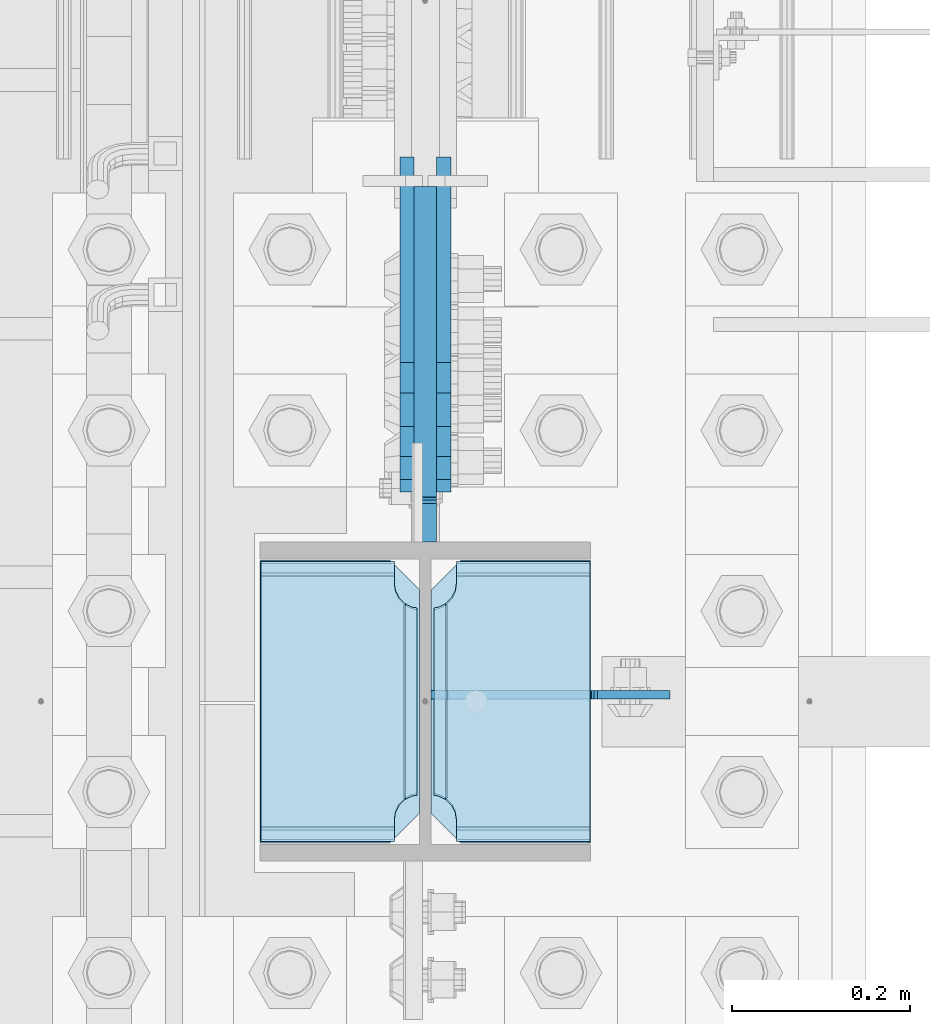
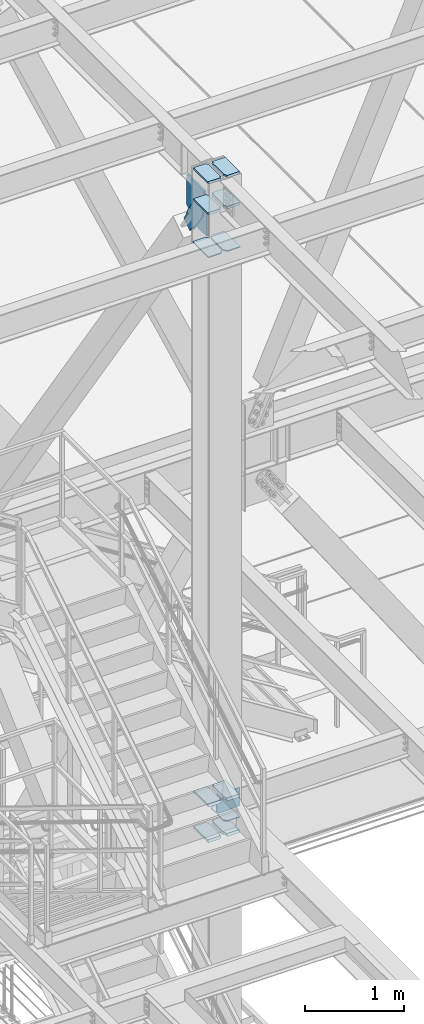
# One storey, part 3120 of 3843: 15 plates, 3 elements without a shape of their own.
"""IFC2X3 building model written with IfcOpenShell, lengths in millimetres."""

from ifc_helpers import new_model, si_unit, frame, origin_with_axes, place, context, subcontext, project, spatial, faceted_brep, material, type_object, element, aggregate, save


model = new_model("IFC2X3")

# Units and contexts
model_context = context("Model", 3, precision=1e-05, world=origin_with_axes())
body_context = subcontext(model_context, "Body", "Model", "MODEL_VIEW")
ifc_project = project(units=[si_unit("LENGTHUNIT", "METRE", prefix="MILLI"), si_unit("AREAUNIT", "SQUARE_METRE"), si_unit("VOLUMEUNIT", "CUBIC_METRE"), si_unit("MASSUNIT", "GRAM", prefix="KILO"), si_unit("TIMEUNIT", "SECOND"), si_unit("PLANEANGLEUNIT", "RADIAN"), si_unit("SOLIDANGLEUNIT", "STERADIAN"), si_unit("THERMODYNAMICTEMPERATUREUNIT", "DEGREE_CELSIUS"), si_unit("LUMINOUSINTENSITYUNIT", "LUMEN")], contexts=[model_context])

# Site, building, storey
site_placement = place(None, origin_with_axes())
site = spatial("IfcSite", under=ifc_project, at=site_placement, CompositionType="ELEMENT")
building_placement = place(site_placement, origin_with_axes())
building = spatial("IfcBuilding", under=site, at=building_placement, Name="Undefined", CompositionType="ELEMENT")
storey_placement = place(building_placement, origin_with_axes())
storey = spatial("IfcBuildingStorey", under=building, at=storey_placement, Name="Undefined", CompositionType="ELEMENT", Elevation=0.0)

# Assembly, plates
assembly_1_placement = place(storey_placement, origin_with_axes())
assembly_1 = element("IfcElementAssembly", 1, at=assembly_1_placement, inside=storey, Name="COLUMN", AssemblyPlace="NOTDEFINED", PredefinedType="RIGID_FRAME")
ifc_material_1 = material(Name="STEEL/A572-50")
plate_type_1 = type_object("IfcPlateType", PredefinedType="NOTDEFINED")
plate_1_placement = place(assembly_1_placement, frame((55745.0625, 20148.55, 41547.5150466346), z_axis=(0.0, 1.0, 0.0), x_axis=(1.0, 0.0, 0.0)))
plate_1 = element("IfcPlate", 2, at=plate_1_placement, type_object=plate_type_1, material=ifc_material_1, Name="STIFFENER", context=body_context, shape_type="Brep", body=[
    faceted_brep([(0.0, -6.3499999046162, 0.0), (0.0, -6.34999999999854, 317.5), (0.0, 6.34999999999854, 317.5), (7.27595761418343e-12, 6.3499999046162, 0.0), (146.049995422363, -6.34999999999854, 317.5), (146.049995422363, 6.34999999999854, 317.5), (179.387496948242, -6.34999999999854, 284.162498474121), (179.387496948242, 6.34999999999854, 284.162498474121), (179.387496948242, -6.34999999999854, 33.3375015258789), (179.387496948242, 6.34999999999854, 33.3375015258789), (146.050003051758, -6.34999999999854, 0.0), (146.050003051758, 6.34999999999854, 0.0)], [[[0, 1, 2, 3]], [[1, 4, 5, 2]], [[4, 6, 7, 5]], [[6, 8, 9, 7]], [[8, 10, 11, 9]], [[10, 0, 3, 11]], [[5, 7, 9, 11, 3, 2]], [[10, 8, 6, 4, 1, 0]]]),
])
plate_2_placement = place(assembly_1_placement, frame((55937.15, 20148.55, 41547.5150466346), z_axis=(0.0, 1.0, 0.0), x_axis=(1.0, 0.0, 0.0)))
plate_2 = element("IfcPlate", 3, at=plate_2_placement, type_object=plate_type_1, material=ifc_material_1, Name="STIFFENER", context=body_context, shape_type="Brep", body=[
    faceted_brep([(0.0, -6.34999999999854, 33.3375015258789), (0.0, -6.34999999999854, 284.162498474121), (0.0, 6.34999999999854, 284.162498474121), (0.0, 6.34999999999854, 33.3375015258789), (33.3375015258789, -6.34999999999854, 317.5), (33.3375015258789, 6.34999999999854, 317.5), (179.387496948242, -6.34999999999854, 317.5), (179.387496948242, 6.34999999999854, 317.5), (179.387496948242, -6.34999999999854, 0.0), (179.387496948242, 6.34999999999854, 0.0), (33.3375015258789, -6.34999999999854, 0.0), (33.3375015258789, 6.34999999999854, 0.0)], [[[0, 1, 2, 3]], [[1, 4, 5, 2]], [[4, 6, 7, 5]], [[6, 8, 9, 7]], [[8, 10, 11, 9]], [[10, 0, 3, 11]], [[5, 7, 9, 11, 3, 2]], [[10, 8, 6, 4, 1, 0]]]),
])
plate_type_2 = type_object("IfcPlateType", PredefinedType="NOTDEFINED")
plate_3_placement = place(assembly_1_placement, frame((56114.95, 20148.55, 34539.2375), z_axis=(0.0, 1.0, 0.0), x_axis=(-1.0, 0.0, 0.0)))
plate_3 = element("IfcPlate", 4, at=plate_3_placement, type_object=plate_type_2, material=ifc_material_1, Name="PLATE", context=body_context, shape_type="Brep", body=[
    faceted_brep([(0.0, -4.76249999999709, 0.0), (0.0, -4.76249999785796, 317.500000005042), (0.0, 4.76250000210712, 317.50000000505), (0.0, 4.76249999999709, 0.0), (144.462501525879, -4.76249999999709, 317.5), (144.462501525879, 4.76249999999709, 317.5), (177.800003051758, -4.76249999999709, 284.162498474121), (177.800003051758, 4.76249999999709, 284.162498474121), (177.800003051758, -4.76249999999709, 33.3375015258789), (177.800003051758, 4.76249999999709, 33.3375015258789), (144.462501525879, -4.76249999999709, 0.0), (144.462501525879, 4.76249999999709, 0.0)], [[[0, 1, 2, 3]], [[1, 4, 5, 2]], [[4, 6, 7, 5]], [[6, 8, 9, 7]], [[8, 10, 11, 9]], [[10, 0, 3, 11]], [[5, 7, 9, 11, 3, 2]], [[10, 8, 6, 4, 1, 0]]]),
])
plate_type_3 = type_object("IfcPlateType", PredefinedType="NOTDEFINED")
plate_4_placement = place(assembly_1_placement, frame((55924.45, 20146.9625, 42076.6875), z_axis=(0.0, 1.0, 0.0), x_axis=(-1.0, 0.0, 0.0)))
plate_4 = element("IfcPlate", 5, at=plate_4_placement, type_object=plate_type_3, material=ifc_material_1, Name="PLATE", context=body_context, shape_type="Brep", body=[
    faceted_brep([(16.0066099053001, 11.1125000000029, 270.167643514866), (16.0066099053001, 11.1125000000029, 50.50735648513), (8.830160850026, -1.31775402112544, 54.1639399157939), (3.17499995231628, -11.1125000000029, 55.059629409523), (3.17499995231628, -11.1125000000029, 265.615370590476), (8.830160850026, -1.31775402112544, 266.511060084205), (28.5750007629395, 11.1125000000029, 304.668390094703), (28.5750007629395, -11.1125000000029, 317.500000047683), (178.593800000002, -11.1125000000029, 317.500000047683), (178.593800000002, 11.1125000000029, 304.668390094703), (178.593800000002, 11.1125000000029, 16.0066099052965), (178.593800000002, -11.1125000000029, 3.17499995231628), (28.5750007629395, -11.1125000000029, 3.17499995231628), (28.5750007629395, 11.1125000000029, 16.0066099052965), (8.830160850026, -11.1125000000029, 266.511060084205), (16.7959640327026, -11.1125000000029, 270.569839531443), (16.7959640327026, 11.1125000000029, 270.569839531443), (23.1176612314957, -11.1125000000029, 276.891536730236), (23.1176612314957, 11.1125000000029, 276.891536730236), (27.1764406787333, -11.1125000000029, 284.857339912913), (27.1764406787333, 11.1125000000029, 284.857339912913), (28.5750007629395, -11.1125000000029, 293.687500762939), (28.5750007629395, 11.1125000000029, 293.687500762939), (28.5750007629395, -11.1125000000029, 26.9874992370605), (28.5750007629395, 11.1125000000029, 26.9874992370605), (27.1764406787333, -11.1125000000029, 35.8176600870866), (27.1764406787333, 11.1125000000029, 35.8176600870866), (23.1176612314957, -11.1125000000029, 43.7834632697632), (23.1176612314957, 11.1125000000029, 43.7834632697632), (16.7959640327026, -11.1125000000029, 50.1051604685563), (16.7959640327026, 11.1125000000029, 50.1051604685563), (8.830160850026, -11.1125000000029, 54.1639399157939)], [[[0, 1, 2, 3, 4, 5]], [[6, 7, 8, 9]], [[10, 11, 12, 13]], [[14, 5, 4]], [[14, 15, 16, 0, 5]], [[15, 17, 18, 16]], [[17, 19, 20, 18]], [[19, 21, 22, 20]], [[22, 21, 7, 6]], [[11, 10, 9, 8]], [[23, 24, 13, 12]], [[23, 25, 26, 24]], [[25, 27, 28, 26]], [[27, 29, 30, 28]], [[30, 29, 31, 2, 1]], [[31, 3, 2]], [[16, 18, 20, 22, 6, 9, 10, 13, 24, 26, 28, 30, 1, 0]], [[31, 29, 27, 25, 23, 12, 11, 8, 7, 21, 19, 17, 15, 14, 4, 3]]]),
])
plate_5_placement = place(assembly_1_placement, frame((55924.45, 20146.9625, 42457.6875), z_axis=(0.0, 1.0, 0.0), x_axis=(-1.0, 0.0, 0.0)))
plate_5 = element("IfcPlate", 6, at=plate_5_placement, type_object=plate_type_3, material=ifc_material_1, Name="PLATE", context=body_context, shape_type="Brep", body=[
    faceted_brep([(16.0066099053001, 11.1125000000029, 270.167643514866), (16.0066099053001, 11.1125000000029, 50.50735648513), (8.830160850026, -1.31719474220154, 54.1639399157939), (3.17499995231628, -11.1125000000029, 55.059629409523), (3.17499995231628, -11.1125000000029, 265.615370590476), (8.830160850026, -1.31719474219426, 266.511060084205), (178.593800000002, 11.1125000000029, 16.0066099052965), (178.593800000002, -11.1125000000029, 3.17499995231628), (28.5750007629395, -11.1125000000029, 3.17499995231628), (28.5750007629395, 11.1125000000029, 16.0066099052965), (28.5750007629395, 11.1125000000029, 304.668390094703), (28.5750007629395, -11.1125000000029, 317.500000047683), (178.593800000002, -11.1125000000029, 317.500000047683), (178.593800000002, 11.1125000000029, 304.668390094703), (8.830160850026, -11.1125000000029, 266.511060084205), (16.7959640327026, -11.1125000000029, 270.569839531443), (16.7959640327026, 11.1125000000029, 270.569839531443), (23.1176612314957, -11.1125000000029, 276.891536730236), (23.1176612314957, 11.1125000000029, 276.891536730236), (27.1764406787333, -11.1125000000029, 284.857339912913), (27.1764406787333, 11.1125000000029, 284.857339912913), (28.5750007629395, -11.1125000000029, 293.687500762939), (28.5750007629395, 11.1125000000029, 293.687500762939), (28.5750007629395, -11.1125000000029, 26.9874992370605), (28.5750007629395, 11.1125000000029, 26.9874992370605), (27.1764406787333, -11.1125000000029, 35.8176600870866), (27.1764406787333, 11.1125000000029, 35.8176600870866), (23.1176612314957, -11.1125000000029, 43.7834632697632), (23.1176612314957, 11.1125000000029, 43.7834632697632), (16.7959640327026, -11.1125000000029, 50.1051604685563), (16.7959640327026, 11.1125000000029, 50.1051604685563), (8.830160850026, -11.1125000000029, 54.1639399157939)], [[[0, 1, 2, 3, 4, 5]], [[6, 7, 8, 9]], [[10, 11, 12, 13]], [[14, 5, 4]], [[14, 15, 16, 0, 5]], [[15, 17, 18, 16]], [[17, 19, 20, 18]], [[19, 21, 22, 20]], [[22, 21, 11, 10]], [[7, 6, 13, 12]], [[23, 24, 9, 8]], [[23, 25, 26, 24]], [[25, 27, 28, 26]], [[27, 29, 30, 28]], [[30, 29, 31, 2, 1]], [[31, 3, 2]], [[16, 18, 20, 22, 10, 13, 6, 9, 24, 26, 28, 30, 1, 0]], [[31, 29, 27, 25, 23, 8, 7, 12, 11, 21, 19, 17, 15, 14, 4, 3]]]),
])
plate_6_placement = place(assembly_1_placement, frame((56115.7438, 20146.9625, 42076.6875), z_axis=(0.0, 1.0, 0.0), x_axis=(-1.0, 0.0, 0.0)))
plate_6 = element("IfcPlate", 7, at=plate_6_placement, type_object=plate_type_3, material=ifc_material_1, Name="PLATE", context=body_context, shape_type="Brep", body=[
    faceted_brep([(162.587190094702, 11.1125000000029, 50.50735648513), (162.587190094702, 11.1125000000029, 270.167643514869), (169.763639149976, -1.31775402112544, 266.511060084205), (175.418800047686, -11.1125000000029, 265.615370590476), (175.418800047686, -11.1125000000029, 55.059629409523), (169.763639149976, -1.31775402112544, 54.1639399157939), (0.0, 11.1125000000029, 304.668390094703), (0.0, -11.1125000000029, 317.500000047683), (150.018799237063, -11.1125000000029, 317.500000047683), (150.018799237063, 11.1125000000029, 304.668390094703), (150.018799237063, 11.1125000000029, 16.0066099052965), (150.018799237063, -11.1125000000029, 3.17499995231628), (0.0, -11.1125000000029, 3.17499995231628), (0.0, 11.1125000000029, 16.0066099052965), (150.018799237063, -11.1125000000029, 293.687500762939), (150.018799237063, 11.1125000000029, 293.687500762939), (151.417359321269, -11.1125000000029, 284.857339912913), (151.417359321269, 11.1125000000029, 284.857339912913), (155.476138768507, -11.1125000000029, 276.891536730236), (155.476138768507, 11.1125000000029, 276.891536730236), (161.7978359673, -11.1125000000029, 270.569839531443), (161.7978359673, 11.1125000000029, 270.569839531443), (169.763639149976, -11.1125000000029, 266.511060084205), (169.763639149976, -11.1125000000029, 54.1639399157939), (161.7978359673, -11.1125000000029, 50.1051604685563), (161.7978359673, 11.1125000000029, 50.1051604685563), (155.476138768507, -11.1125000000029, 43.7834632697632), (155.476138768507, 11.1125000000029, 43.7834632697632), (151.417359321269, -11.1125000000029, 35.8176600870866), (151.417359321269, 11.1125000000029, 35.8176600870866), (150.018799237063, -11.1125000000029, 26.9874992370605), (150.018799237063, 11.1125000000029, 26.9874992370605)], [[[0, 1, 2, 3, 4, 5]], [[6, 7, 8, 9]], [[10, 11, 12, 13]], [[13, 12, 7, 6]], [[14, 15, 9, 8]], [[14, 16, 17, 15]], [[16, 18, 19, 17]], [[18, 20, 21, 19]], [[21, 20, 22, 2, 1]], [[22, 3, 2]], [[23, 5, 4]], [[23, 24, 25, 0, 5]], [[24, 26, 27, 25]], [[26, 28, 29, 27]], [[28, 30, 31, 29]], [[31, 30, 11, 10]], [[25, 27, 29, 31, 10, 13, 6, 9, 15, 17, 19, 21, 1, 0]], [[11, 30, 28, 26, 24, 23, 4, 3, 22, 20, 18, 16, 14, 8, 7, 12]]]),
])
plate_7_placement = place(assembly_1_placement, frame((56115.7438, 20146.9625, 42457.6875), z_axis=(0.0, 1.0, 0.0), x_axis=(-1.0, 0.0, 0.0)))
plate_7 = element("IfcPlate", 8, at=plate_7_placement, type_object=plate_type_3, material=ifc_material_1, Name="PLATE", context=body_context, shape_type="Brep", body=[
    faceted_brep([(162.587190094702, 11.1125000000029, 50.50735648513), (162.587190094702, 11.1125000000029, 270.167643514869), (169.763639149976, -1.31719474220154, 266.511060084205), (175.418800047686, -11.1125000000029, 265.615370590476), (175.418800047686, -11.1125000000029, 55.059629409523), (169.763639149976, -1.31719474220154, 54.1639399157939), (150.018799237063, 11.1125000000029, 16.0066099052965), (150.018799237063, -11.1125000000029, 3.17499995231628), (0.0, -11.1125000000029, 3.17499995231628), (0.0, 11.1125000000029, 16.0066099052965), (0.0, 11.1125000000029, 304.668390094703), (0.0, -11.1125000000029, 317.500000047683), (150.018799237063, -11.1125000000029, 317.500000047683), (150.018799237063, 11.1125000000029, 304.668390094703), (150.018799237063, -11.1125000000029, 293.687500762939), (150.018799237063, 11.1125000000029, 293.687500762939), (151.417359321269, -11.1125000000029, 284.857339912913), (151.417359321269, 11.1125000000029, 284.857339912913), (155.476138768507, -11.1125000000029, 276.891536730236), (155.476138768507, 11.1125000000029, 276.891536730236), (161.7978359673, -11.1125000000029, 270.569839531443), (161.7978359673, 11.1125000000029, 270.569839531443), (169.763639149976, -11.1125000000029, 266.511060084205), (169.763639149976, -11.1125000000029, 54.1639399157939), (161.7978359673, -11.1125000000029, 50.1051604685563), (161.7978359673, 11.1125000000029, 50.1051604685563), (155.476138768507, -11.1125000000029, 43.7834632697632), (155.476138768507, 11.1125000000029, 43.7834632697632), (151.417359321269, -11.1125000000029, 35.8176600870866), (151.417359321269, 11.1125000000029, 35.8176600870866), (150.018799237063, -11.1125000000029, 26.9874992370605), (150.018799237063, 11.1125000000029, 26.9874992370605)], [[[0, 1, 2, 3, 4, 5]], [[6, 7, 8, 9]], [[10, 11, 12, 13]], [[9, 8, 11, 10]], [[14, 15, 13, 12]], [[14, 16, 17, 15]], [[16, 18, 19, 17]], [[18, 20, 21, 19]], [[21, 20, 22, 2, 1]], [[22, 3, 2]], [[23, 5, 4]], [[23, 24, 25, 0, 5]], [[24, 26, 27, 25]], [[26, 28, 29, 27]], [[28, 30, 31, 29]], [[31, 30, 7, 6]], [[25, 27, 29, 31, 6, 9, 10, 13, 15, 17, 19, 21, 1, 0]], [[7, 30, 28, 26, 24, 23, 4, 3, 22, 20, 18, 16, 14, 12, 11, 8]]]),
])
plate_type_4 = type_object("IfcPlateType", PredefinedType="NOTDEFINED")
plate_8_placement = place(assembly_1_placement, frame((55930.8, 20885.9556735903, 42065.575), z_axis=(0.0, 0.0, -1.0), x_axis=(0.0, -1.0, 0.0)))
plate_8 = element("IfcPlate", 9, at=plate_8_placement, type_object=plate_type_4, material=ifc_material_1, Name="CB", context=body_context, shape_type="Brep", body=[
    faceted_brep([(348.468173590347, -12.6999999999971, 0.0), (348.468173590347, 12.6999999999971, 0.0), (348.468173590347, 12.6999999999971, 25.4000001907334), (348.468173590347, -12.6999999999971, 25.4000001907334), (349.434903512934, 12.6999999999971, 30.2600797087798), (349.434903512934, -12.6999999999971, 30.2600797087798), (352.187917413412, 12.6999999999971, 34.3802561769335), (352.187917413412, -12.6999999999971, 34.3802561769335), (356.308093881566, 12.6999999999971, 37.1332700774074), (356.308093881566, -12.6999999999971, 37.1332700774074), (361.168173399612, 12.6999999999971, 38.0999999999985), (361.168173399612, -12.6999999999971, 38.0999999999985), (399.268173590346, -12.6999999999971, 38.0999999999985), (399.268173590346, 12.6999999999971, 38.0999999999985), (0.0, -12.6999999999971, 0.0), (0.0, -12.6999999999971, 369.765843106718), (0.0, 12.6999999999971, 369.765843106718), (0.0, 12.6999999999971, 0.0), (223.964095792653, -12.6999999999971, 524.40995336543), (223.964095792653, 12.6999999999971, 524.40995336543), (399.268173590346, -12.6999999999971, 524.40995336543), (399.268173590346, 12.6999999999971, 524.40995336543)], [[[0, 1, 2, 3]], [[3, 2, 4, 5]], [[5, 4, 6, 7]], [[7, 6, 8, 9]], [[9, 8, 10, 11]], [[12, 11, 10, 13]], [[14, 15, 16, 17]], [[15, 18, 19, 16]], [[18, 20, 21, 19]], [[21, 20, 12, 13]], [[8, 6, 4, 2, 1, 17, 16, 19, 21, 13, 10]], [[14, 17, 1, 0]], [[20, 18, 15, 14, 0, 3, 5, 7, 9, 11, 12]]]),
])

# Assembly, plate
assembly_2_placement = place(storey_placement, origin_with_axes())
assembly_2 = element("IfcElementAssembly", 10, at=assembly_2_placement, inside=storey, AssemblyPlace="NOTDEFINED", PredefinedType="RIGID_FRAME")
ifc_material_2 = material(Name="STEEL/A36")
plate_type_5 = type_object("IfcPlateType", PredefinedType="NOTDEFINED")
plate_9_placement = place(assembly_2_placement, frame((55910.1625, 20879.4458543125, 41567.8473840328), z_axis=(0.0, -0.822893061718405, -0.568196276805568), x_axis=(0.0, 0.568196276805568, -0.822893061718405)))
plate_9 = element("IfcPlate", 11, at=plate_9_placement, type_object=plate_type_5, material=ifc_material_2, context=body_context, shape_type="Brep", body=[
    faceted_brep([(0.0, -7.9375, 0.0), (-101.600000000672, -7.9375, -21.7975798491389), (-101.600000000672, 7.9375, -21.7975798491389), (0.0, 7.9375, 0.0), (-320.921138855079, -7.9375, -21.7975798491389), (-320.921138855079, 7.9375, -21.7975798491389), (-357.371735787896, -7.9375, -14.5471053208457), (-357.371735787896, 7.9375, -14.5471053208457), (-388.273059763174, -7.9375, 6.10049924286432), (-388.273059763174, 7.9375, 6.10049924286432), (-408.920664326874, -7.9375, 37.0018232181319), (-408.920664326874, 7.9375, 37.0018232181319), (-416.171138855196, -7.9375, 73.4524201520326), (-416.171138855196, 7.9375, 73.4524201520326), (-408.920664326884, -7.9375, 109.903017084842), (-408.920664326884, 7.9375, 109.903017084842), (-388.273059763185, -7.9375, 140.804341060124), (-388.273059763185, 7.9375, 140.804341060124), (-357.371735787903, -7.9375, 161.451945623819), (-357.371735787903, 7.9375, 161.451945623819), (-320.921138854563, -7.9375, 168.702420152127), (-320.921138854563, 7.9375, 168.702420152127), (-101.600000000686, -7.9375, 168.702420152142), (-101.600000000686, 7.9375, 168.702420152142), (-3.63797880709171e-12, -7.9375, 146.90484030301), (-3.63797880709171e-12, 7.9375, 146.90484030301), (69.8500000004642, -7.9375, 146.904840303017), (69.8500000004642, 7.9375, 146.904840303017), (69.850000000486, -7.9375, 2.91038304567337e-11), (69.850000000486, 7.9375, 2.91038304567337e-11)], [[[0, 1, 2, 3]], [[1, 4, 5, 2]], [[4, 6, 7, 5]], [[6, 8, 9, 7]], [[8, 10, 11, 9]], [[10, 12, 13, 11]], [[12, 14, 15, 13]], [[14, 16, 17, 15]], [[16, 18, 19, 17]], [[18, 20, 21, 19]], [[20, 22, 23, 21]], [[22, 24, 25, 23]], [[24, 26, 27, 25]], [[26, 28, 29, 27]], [[28, 0, 3, 29]], [[5, 7, 9, 11, 13, 15, 17, 19, 21, 23, 25, 27, 29, 3, 2]], [[28, 26, 24, 22, 20, 18, 16, 14, 12, 10, 8, 6, 4, 1, 0]]]),
])
aggregate(assembly_2, [plate_9])

assembly_3_placement = place(storey_placement, origin_with_axes())
assembly_3 = element("IfcElementAssembly", 12, at=assembly_3_placement, inside=storey, AssemblyPlace="NOTDEFINED", PredefinedType="RIGID_FRAME")
plate_10_placement = place(assembly_3_placement, frame((55951.4375, 20879.4458543125, 41567.8473840328), z_axis=(0.0, -0.822893061718405, -0.568196276805568), x_axis=(0.0, 0.568196276805568, -0.822893061718405)))
plate_10 = element("IfcPlate", 13, at=plate_10_placement, type_object=plate_type_5, material=ifc_material_2, context=body_context, shape_type="Brep", body=[
    faceted_brep([(0.0, -7.9375, 0.0), (-101.600000000672, -7.9375, -21.7975798491389), (-101.600000000672, 7.9375, -21.7975798491389), (0.0, 7.9375, 0.0), (-320.921138855079, -7.9375, -21.7975798491389), (-320.921138855079, 7.9375, -21.7975798491389), (-357.371735787896, -7.9375, -14.5471053208457), (-357.371735787896, 7.9375, -14.5471053208457), (-388.273059763174, -7.9375, 6.10049924286432), (-388.273059763174, 7.9375, 6.10049924286432), (-408.920664326874, -7.9375, 37.0018232181319), (-408.920664326874, 7.9375, 37.0018232181319), (-416.171138855196, -7.9375, 73.4524201520326), (-416.171138855196, 7.9375, 73.4524201520326), (-408.920664326884, -7.9375, 109.903017084842), (-408.920664326884, 7.9375, 109.903017084842), (-388.273059763185, -7.9375, 140.804341060124), (-388.273059763185, 7.9375, 140.804341060124), (-357.371735787903, -7.9375, 161.451945623819), (-357.371735787903, 7.9375, 161.451945623819), (-320.921138854563, -7.9375, 168.702420152127), (-320.921138854563, 7.9375, 168.702420152127), (-101.600000000686, -7.9375, 168.702420152142), (-101.600000000686, 7.9375, 168.702420152142), (-3.63797880709171e-12, -7.9375, 146.90484030301), (-3.63797880709171e-12, 7.9375, 146.90484030301), (69.8500000004642, -7.9375, 146.904840303017), (69.8500000004642, 7.9375, 146.904840303017), (69.850000000486, -7.9375, 2.91038304567337e-11), (69.850000000486, 7.9375, 2.91038304567337e-11)], [[[0, 1, 2, 3]], [[1, 4, 5, 2]], [[4, 6, 7, 5]], [[6, 8, 9, 7]], [[8, 10, 11, 9]], [[10, 12, 13, 11]], [[12, 14, 15, 13]], [[14, 16, 17, 15]], [[16, 18, 19, 17]], [[18, 20, 21, 19]], [[20, 22, 23, 21]], [[22, 24, 25, 23]], [[24, 26, 27, 25]], [[26, 28, 29, 27]], [[28, 0, 3, 29]], [[5, 7, 9, 11, 13, 15, 17, 19, 21, 23, 25, 27, 29, 3, 2]], [[28, 26, 24, 22, 20, 18, 16, 14, 12, 10, 8, 6, 4, 1, 0]]]),
])
aggregate(assembly_3, [plate_10])

# Plate
plate_type_6 = type_object("IfcPlateType", PredefinedType="NOTDEFINED")
plate_11_placement = place(assembly_1_placement, frame((55924.45, 20148.55, 34359.85), z_axis=(0.0, 1.0, 0.0), x_axis=(-1.0, 0.0, 0.0)))
plate_11 = element("IfcPlate", 14, at=plate_11_placement, type_object=plate_type_6, material=ifc_material_1, Name="PLATE", context=body_context, shape_type="Brep", body=[
    faceted_brep([(16.7959640327026, 10.8922022167681, 267.394839531444), (17.8396965694919, 12.6999999999971, 268.438572068233), (17.8396965694919, 12.6999999999971, 49.061427931767), (16.7959640327026, 10.8922022167681, 50.1051604685563), (8.830160850026, -2.90497361872258, 54.1639399157939), (3.17499995231628, -12.6999999999971, 55.059629409523), (3.17499995231628, -12.6999999999971, 262.440370590477), (8.830160850026, -2.90497361872258, 263.33606008421), (28.5750007629395, 12.6999999999971, 299.65980343051), (28.5750007629395, -12.6999999999971, 314.324500047685), (178.593800000002, -12.6999999999971, 314.324500047685), (178.593800000002, 12.6999999999971, 299.65980343051), (178.593800000002, 12.6999999999971, 17.8391965694937), (178.593800000002, -12.6999999999971, 3.174499952318), (28.5750007629395, -12.6999999999971, 3.174499952318), (28.5750007629395, 12.6999999999971, 17.8391965694937), (8.830160850026, -12.6999999999971, 263.33606008421), (16.7959640327026, -12.6999999999971, 267.394839531444), (23.1176612314957, -12.6999999999971, 273.716536730237), (23.1176612314957, 12.6999999999971, 273.716536730237), (27.1764406787333, -12.6999999999971, 281.682339912913), (27.1764406787333, 12.6999999999971, 281.682339912913), (28.5750007629395, -12.6999999999971, 290.512500762939), (28.5750007629395, 12.6999999999971, 290.512500762939), (28.5750007629395, -12.6999999999971, 26.9874992370605), (28.5750007629395, 12.6999999999971, 26.9874992370605), (27.1764406787333, -12.6999999999971, 35.8176600870866), (27.1764406787333, 12.6999999999971, 35.8176600870866), (23.1176612314957, -12.6999999999971, 43.7834632697632), (23.1176612314957, 12.6999999999971, 43.7834632697632), (16.7959640327026, -12.6999999999971, 50.1051604685563), (8.830160850026, -12.6999999999971, 54.1639399157939)], [[[0, 1, 2, 3, 4, 5, 6, 7]], [[8, 9, 10, 11]], [[12, 13, 14, 15]], [[16, 7, 6]], [[16, 17, 0, 7]], [[17, 18, 19, 1, 0]], [[18, 20, 21, 19]], [[20, 22, 23, 21]], [[23, 22, 9, 8]], [[13, 12, 11, 10]], [[24, 25, 15, 14]], [[24, 26, 27, 25]], [[26, 28, 29, 27]], [[29, 28, 30, 3, 2]], [[30, 31, 4, 3]], [[31, 5, 4]], [[19, 21, 23, 8, 11, 12, 15, 25, 27, 29, 2, 1]], [[31, 30, 28, 26, 24, 14, 13, 10, 9, 22, 20, 18, 17, 16, 6, 5]]]),
])

plate_12_placement = place(assembly_1_placement, frame((55924.45, 20148.55, 34798.0), z_axis=(0.0, 1.0, 0.0), x_axis=(-1.0, 0.0, 0.0)))
plate_12 = element("IfcPlate", 15, at=plate_12_placement, type_object=plate_type_6, material=ifc_material_1, Name="PLATE", context=body_context, shape_type="Brep", body=[
    faceted_brep([(16.7959640327026, 10.8922022167681, 267.394839531444), (17.8396965694919, 12.6999999999971, 268.438572068233), (17.8396965694919, 12.6999999999971, 49.061427931767), (16.7959640327026, 10.8922022167681, 50.1051604685563), (8.830160850026, -2.90497361872258, 54.1639399157939), (3.17499995231628, -12.6999999999971, 55.059629409523), (3.17499995231628, -12.6999999999971, 262.440370590477), (8.830160850026, -2.90497361872258, 263.33606008421), (28.5750007629395, 12.6999999999971, 299.65980343051), (28.5750007629395, -12.6999999999971, 314.324500047685), (178.593800000002, -12.6999999999971, 314.324500047685), (178.593800000002, 12.6999999999971, 299.65980343051), (178.593800000002, 12.6999999999971, 17.8391965694937), (178.593800000002, -12.6999999999971, 3.174499952318), (28.5750007629395, -12.6999999999971, 3.174499952318), (28.5750007629395, 12.6999999999971, 17.8391965694937), (8.830160850026, -12.6999999999971, 263.33606008421), (16.7959640327026, -12.6999999999971, 267.394839531444), (23.1176612314957, -12.6999999999971, 273.716536730237), (23.1176612314957, 12.6999999999971, 273.716536730237), (27.1764406787333, -12.6999999999971, 281.682339912913), (27.1764406787333, 12.6999999999971, 281.682339912913), (28.5750007629395, -12.6999999999971, 290.512500762939), (28.5750007629395, 12.6999999999971, 290.512500762939), (28.5750007629395, -12.6999999999971, 26.9874992370605), (28.5750007629395, 12.6999999999971, 26.9874992370605), (27.1764406787333, -12.6999999999971, 35.8176600870866), (27.1764406787333, 12.6999999999971, 35.8176600870866), (23.1176612314957, -12.6999999999971, 43.7834632697632), (23.1176612314957, 12.6999999999971, 43.7834632697632), (16.7959640327026, -12.6999999999971, 50.1051604685563), (8.830160850026, -12.6999999999971, 54.1639399157939)], [[[0, 1, 2, 3, 4, 5, 6, 7]], [[8, 9, 10, 11]], [[12, 13, 14, 15]], [[16, 7, 6]], [[16, 17, 0, 7]], [[17, 18, 19, 1, 0]], [[18, 20, 21, 19]], [[20, 22, 23, 21]], [[23, 22, 9, 8]], [[13, 12, 11, 10]], [[24, 25, 15, 14]], [[24, 26, 27, 25]], [[26, 28, 29, 27]], [[29, 28, 30, 3, 2]], [[30, 31, 4, 3]], [[31, 5, 4]], [[19, 21, 23, 8, 11, 12, 15, 25, 27, 29, 2, 1]], [[31, 30, 28, 26, 24, 14, 13, 10, 9, 22, 20, 18, 17, 16, 6, 5]]]),
])

plate_13_placement = place(assembly_1_placement, frame((56115.7438, 20148.55, 34359.85), z_axis=(0.0, 1.0, 0.0), x_axis=(-1.0, 0.0, 0.0)))
plate_13 = element("IfcPlate", 16, at=plate_13_placement, type_object=plate_type_6, material=ifc_material_1, Name="PLATE", context=body_context, shape_type="Brep", body=[
    faceted_brep([(161.7978359673, 10.8922022167681, 50.1051604685563), (160.75410343051, 12.6999999999971, 49.061427931767), (160.75410343051, 12.6999999999971, 268.438572068233), (161.7978359673, 10.8922022167681, 267.394839531444), (169.763639149976, -2.90497361872258, 263.336060084206), (175.418800047686, -12.6999999999971, 262.440370590477), (175.418800047686, -12.6999999999971, 55.059629409523), (169.763639149976, -2.90497361872258, 54.1639399157939), (0.0, 12.6999999999971, 299.65980343051), (0.0, -12.6999999999971, 314.324500047685), (150.018799237063, -12.6999999999971, 314.324500047685), (150.018799237063, 12.6999999999971, 299.65980343051), (150.018799237063, 12.6999999999971, 17.8391965694937), (150.018799237063, -12.6999999999971, 3.174499952318), (0.0, -12.6999999999971, 3.17449995232164), (0.0, 12.6999999999971, 17.8391965694973), (150.018799237063, -12.6999999999971, 290.512500762939), (150.018799237063, 12.6999999999971, 290.512500762939), (151.417359321269, -12.6999999999971, 281.682339912913), (151.417359321269, 12.6999999999971, 281.682339912913), (155.476138768507, -12.6999999999971, 273.716536730237), (155.476138768507, 12.6999999999971, 273.716536730237), (161.7978359673, -12.6999999999971, 267.394839531444), (169.763639149976, -12.6999999999971, 263.336060084206), (169.763639149976, -12.6999999999971, 54.1639399157939), (161.7978359673, -12.6999999999971, 50.1051604685563), (155.476138768507, -12.6999999999971, 43.7834632697632), (155.476138768507, 12.6999999999971, 43.7834632697632), (151.417359321269, -12.6999999999971, 35.8176600870866), (151.417359321269, 12.6999999999971, 35.8176600870866), (150.018799237063, -12.6999999999971, 26.9874992370605), (150.018799237063, 12.6999999999971, 26.9874992370605)], [[[0, 1, 2, 3, 4, 5, 6, 7]], [[8, 9, 10, 11]], [[12, 13, 14, 15]], [[15, 14, 9, 8]], [[16, 17, 11, 10]], [[16, 18, 19, 17]], [[18, 20, 21, 19]], [[21, 20, 22, 3, 2]], [[22, 23, 4, 3]], [[23, 5, 4]], [[24, 7, 6]], [[24, 25, 0, 7]], [[25, 26, 27, 1, 0]], [[26, 28, 29, 27]], [[28, 30, 31, 29]], [[31, 30, 13, 12]], [[27, 29, 31, 12, 15, 8, 11, 17, 19, 21, 2, 1]], [[13, 30, 28, 26, 25, 24, 6, 5, 23, 22, 20, 18, 16, 10, 9, 14]]]),
])

plate_14_placement = place(assembly_1_placement, frame((56115.7438, 20148.55, 34798.0), z_axis=(0.0, 1.0, 0.0), x_axis=(-1.0, 0.0, 0.0)))
plate_14 = element("IfcPlate", 17, at=plate_14_placement, type_object=plate_type_6, material=ifc_material_1, Name="PLATE", context=body_context, shape_type="Brep", body=[
    faceted_brep([(161.7978359673, 10.8922022167681, 50.1051604685563), (160.75410343051, 12.6999999999971, 49.061427931767), (160.75410343051, 12.6999999999971, 268.438572068233), (161.7978359673, 10.8922022167681, 267.394839531444), (169.763639149976, -2.90497361872258, 263.336060084206), (175.418800047686, -12.6999999999971, 262.440370590477), (175.418800047686, -12.6999999999971, 55.059629409523), (169.763639149976, -2.90497361872258, 54.1639399157939), (0.0, 12.6999999999971, 299.65980343051), (0.0, -12.6999999999971, 314.324500047685), (150.018799237063, -12.6999999999971, 314.324500047685), (150.018799237063, 12.6999999999971, 299.65980343051), (150.018799237063, 12.6999999999971, 17.8391965694937), (150.018799237063, -12.6999999999971, 3.174499952318), (0.0, -12.6999999999971, 3.17449995232164), (0.0, 12.6999999999971, 17.8391965694973), (150.018799237063, -12.6999999999971, 290.512500762939), (150.018799237063, 12.6999999999971, 290.512500762939), (151.417359321269, -12.6999999999971, 281.682339912913), (151.417359321269, 12.6999999999971, 281.682339912913), (155.476138768507, -12.6999999999971, 273.716536730237), (155.476138768507, 12.6999999999971, 273.716536730237), (161.7978359673, -12.6999999999971, 267.394839531444), (169.763639149976, -12.6999999999971, 263.336060084206), (169.763639149976, -12.6999999999971, 54.1639399157939), (161.7978359673, -12.6999999999971, 50.1051604685563), (155.476138768507, -12.6999999999971, 43.7834632697632), (155.476138768507, 12.6999999999971, 43.7834632697632), (151.417359321269, -12.6999999999971, 35.8176600870866), (151.417359321269, 12.6999999999971, 35.8176600870866), (150.018799237063, -12.6999999999971, 26.9874992370605), (150.018799237063, 12.6999999999971, 26.9874992370605)], [[[0, 1, 2, 3, 4, 5, 6, 7]], [[8, 9, 10, 11]], [[12, 13, 14, 15]], [[15, 14, 9, 8]], [[16, 17, 11, 10]], [[16, 18, 19, 17]], [[18, 20, 21, 19]], [[21, 20, 22, 3, 2]], [[22, 23, 4, 3]], [[23, 5, 4]], [[24, 7, 6]], [[24, 25, 0, 7]], [[25, 26, 27, 1, 0]], [[26, 28, 29, 27]], [[28, 30, 31, 29]], [[31, 30, 13, 12]], [[27, 29, 31, 12, 15, 8, 11, 17, 19, 21, 2, 1]], [[13, 30, 28, 26, 25, 24, 6, 5, 23, 22, 20, 18, 16, 10, 9, 14]]]),
])

plate_type_7 = type_object("IfcPlateType", PredefinedType="NOTDEFINED")
plate_15_placement = place(assembly_1_placement, frame((55937.15, 20315.2379999161, 34563.05), z_axis=(0.707106781186548, 0.0, 0.707106781186548), x_axis=(0.707106781186548, 0.0, -0.707106781186548)))
plate_15 = element("IfcPlate", 18, at=plate_15_placement, type_object=plate_type_7, material=ifc_material_1, Name="PLATE", context=body_context, shape_type="Brep", body=[
    faceted_brep([(0.0, -4.76249999999709, 0.0), (-143.684097936422, -4.76250000000073, 143.684097936413), (-143.684097936422, 4.76250000000073, 143.684097936413), (0.0, 4.76249999999709, 0.0), (-143.684097936422, -4.76250000000073, 170.624866299499), (-143.684097936422, 4.76250000000073, 170.624866299499), (-30.3083642736183, -4.76250000000073, 284.000599692597), (-30.3083642736183, 4.76250000000073, 284.000599692597), (-26.1881878054792, -4.76250000000073, 281.247585792124), (-26.1881878054792, 4.76250000000073, 281.247585792124), (-21.32810828744, -4.76250000000073, 280.28085586954), (-21.32810828744, 4.76250000000073, 280.28085586954), (-16.4680287694082, -4.76250000000073, 281.247585792131), (-16.4680287694082, 4.76250000000073, 281.247585792131), (-12.3478523012618, -4.76250000000073, 284.000599692597), (-12.3478523012618, 4.76250000000073, 284.000599692597), (41.5336845597394, -4.76250000000073, 337.882136553599), (41.5336845597394, 4.76250000000073, 337.882136553599), (203.178294738207, -4.76250000000073, 176.237526375131), (203.178294738207, 4.76250000000073, 176.237526375131), (26.9407683631998, -4.76249999999709, 1.30967237055302e-10), (26.9407683631998, 4.76249999999709, 1.30967237055302e-10)], [[[0, 1, 2, 3]], [[1, 4, 5, 2]], [[4, 6, 7, 5]], [[6, 8, 9, 7]], [[8, 10, 11, 9]], [[10, 12, 13, 11]], [[12, 14, 15, 13]], [[14, 16, 17, 15]], [[16, 18, 19, 17]], [[18, 20, 21, 19]], [[20, 0, 3, 21]], [[5, 7, 9, 11, 13, 15, 17, 19, 21, 3, 2]], [[20, 18, 16, 14, 12, 10, 8, 6, 4, 1, 0]]]),
])

aggregate(assembly_1, [plate_1, plate_2, plate_4, plate_5, plate_6, plate_7, plate_8, plate_11, plate_12, plate_13, plate_14, plate_3, plate_15])

save(model, "model.ifc")
